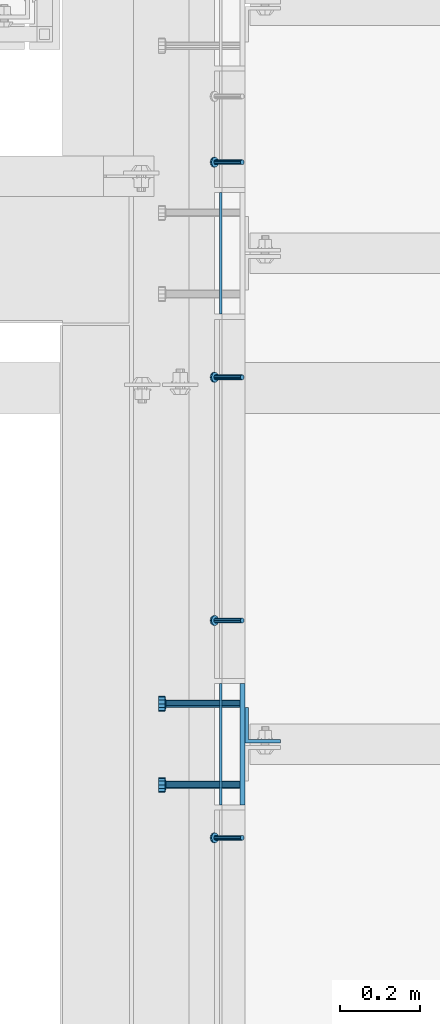
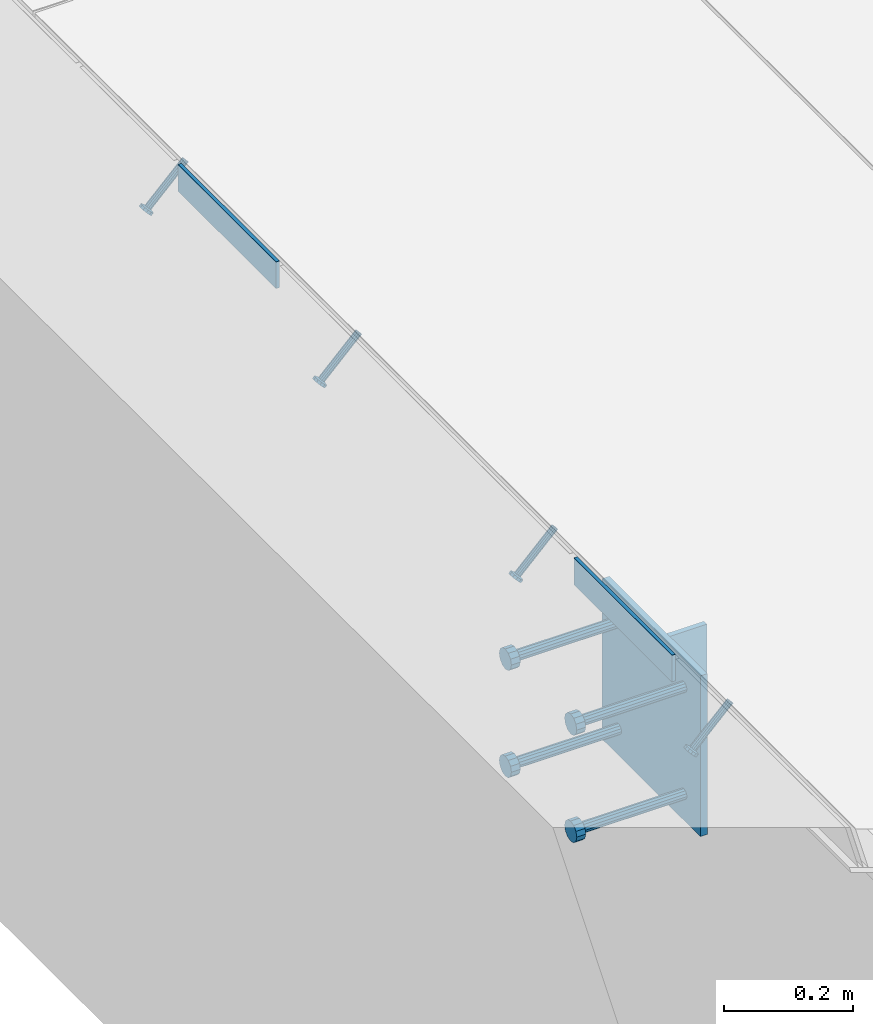
# One storey, part 2074 of 3843: 8 beams, 4 members, 6 elements without a shape of their own.
"""IFC2X3 building model written with IfcOpenShell, lengths in millimetres."""

from ifc_helpers import new_model, si_unit, frame, origin_with_axes, place, context, subcontext, project, spatial, faceted_brep, material, type_object, element, aggregate, save


model = new_model("IFC2X3")

# Units and contexts
model_context = context("Model", 3, precision=1e-05, world=origin_with_axes())
body_context = subcontext(model_context, "Body", "Model", "MODEL_VIEW")
ifc_project = project(units=[si_unit("LENGTHUNIT", "METRE", prefix="MILLI"), si_unit("AREAUNIT", "SQUARE_METRE"), si_unit("VOLUMEUNIT", "CUBIC_METRE"), si_unit("MASSUNIT", "GRAM", prefix="KILO"), si_unit("TIMEUNIT", "SECOND"), si_unit("PLANEANGLEUNIT", "RADIAN"), si_unit("SOLIDANGLEUNIT", "STERADIAN"), si_unit("THERMODYNAMICTEMPERATUREUNIT", "DEGREE_CELSIUS"), si_unit("LUMINOUSINTENSITYUNIT", "LUMEN")], contexts=[model_context])

# Site, building, storey
site_placement = place(None, origin_with_axes())
site = spatial("IfcSite", under=ifc_project, at=site_placement, CompositionType="ELEMENT")
building_placement = place(site_placement, origin_with_axes())
building = spatial("IfcBuilding", under=site, at=building_placement, Name="Undefined", CompositionType="ELEMENT")
storey_placement = place(building_placement, origin_with_axes())
storey = spatial("IfcBuildingStorey", under=building, at=storey_placement, Name="Undefined", CompositionType="ELEMENT", Elevation=0.0)

# Assembly, beam
assembly_1_placement = place(storey_placement, origin_with_axes())
assembly_1 = element("IfcElementAssembly", 1, at=assembly_1_placement, inside=storey, Name="EMBED PLATE", AssemblyPlace="NOTDEFINED", PredefinedType="RIGID_FRAME")
ifc_material_1 = material(Name="STEEL/A36")
beam_type_1 = type_object("IfcBeamType", PredefinedType="NOTDEFINED")
beam_1_placement = place(assembly_1_placement, frame((56080.0250030518, 17306.925, 30454.6), z_axis=(0.0, 0.0, 1.0), x_axis=(0.0, 1.0, 0.0)))
beam_1 = element("IfcBeam", 2, at=beam_1_placement, type_object=beam_type_1, material=ifc_material_1, Name="PLATE", context=body_context, shape_type="Brep", body=[
    faceted_brep([(0.0, 3.17499999999927, -25.4000000000015), (0.0, 3.17499999999927, 25.4000000000015), (304.800000000003, 3.17500000000291, 25.4000000000015), (304.800000000003, 3.17500000000291, -25.4000000000015), (0.0, -3.17499999999927, 25.4000000000015), (304.800000000003, -3.17500000000291, 25.4000000000015), (0.0, -3.17499999999927, -25.4000000000015), (304.800000000003, -3.17500000000291, -25.4000000000015)], [[[0, 1, 2, 3]], [[1, 4, 5, 2]], [[4, 6, 7, 5]], [[6, 0, 3, 7]], [[5, 7, 3, 2]], [[6, 4, 1, 0]]]),
])
aggregate(assembly_1, [beam_1])

assembly_2_placement = place(storey_placement, origin_with_axes())
assembly_2 = element("IfcElementAssembly", 3, at=assembly_2_placement, inside=storey, Name="EMBED PLATE", AssemblyPlace="NOTDEFINED", PredefinedType="RIGID_FRAME")
beam_2_placement = place(assembly_2_placement, frame((56080.0250030517, 16076.6125, 30454.6), z_axis=(0.0, 0.0, 1.0), x_axis=(0.0, 1.0, 0.0)))
beam_2 = element("IfcBeam", 4, at=beam_2_placement, type_object=beam_type_1, material=ifc_material_1, Name="PLATE", context=body_context, shape_type="Brep", body=[
    faceted_brep([(0.0, 3.17499999999927, -25.4000000000015), (0.0, 3.17499999999927, 25.4000000000015), (304.800000000003, 3.17500000000291, 25.4000000000015), (304.800000000003, 3.17500000000291, -25.4000000000015), (0.0, -3.17499999999927, 25.4000000000015), (304.800000000003, -3.17500000000291, 25.4000000000015), (0.0, -3.17499999999927, -25.4000000000015), (304.800000000003, -3.17500000000291, -25.4000000000015)], [[[0, 1, 2, 3]], [[1, 4, 5, 2]], [[4, 6, 7, 5]], [[6, 0, 3, 7]], [[5, 7, 3, 2]], [[6, 4, 1, 0]]]),
])

# Assembly, member
assembly_3_placement = place(storey_placement, origin_with_axes())
assembly_3 = element("IfcElementAssembly", 5, at=assembly_3_placement, inside=storey, Name="ANGLE", AssemblyPlace="NOTDEFINED", PredefinedType="RIGID_FRAME")
ifc_material_2 = material(Name="STEEL/A108")
member_type = type_object("IfcMemberType", PredefinedType="NOTDEFINED")
member_1_placement = place(assembly_3_placement, frame((56134.0000007283, 17687.9250728612, 30422.8500045777), z_axis=(0.0, -1.0, 0.0), x_axis=(-0.707106781186548, 0.0, -0.707106781186548)))
member_1 = element("IfcMember", 6, at=member_1_placement, type_object=member_type, material=ifc_material_2, Name="HEADED STUD ANCHOR", context=body_context, shape_type="Brep", body=[
    faceted_brep([(7.27595761418343e-12, -3.18000006675175, 5.5), (0.0, -5.49999999998363, 3.1800000667572), (94.4879985803855, -5.50000000011278, 3.1800000667572), (94.4879985803782, -3.18000006687362, 5.5), (0.0, -6.3499999046162, 0.0), (94.4879985803855, -6.34999990474535, 0.0), (0.0, -5.49999999998363, -3.1800000667572), (94.4879985803855, -5.50000000011278, -3.1800000667572), (7.27595761418343e-12, -3.18000006675175, -5.5), (94.4879985803782, -3.18000006687362, -5.5), (7.27595761418343e-12, -1.81898940354586e-12, -6.34999990463257), (94.4879985803782, -1.20053300634027e-10, -6.34999990463257), (0.0, 3.18000006675175, -5.5), (94.4879985803709, 3.18000006663351, -5.5), (7.27595761418343e-12, 5.49999999998363, -3.1800000667572), (94.4879985803709, 5.49999999987267, -3.1800000667572), (7.27595761418343e-12, 6.3499999046162, 0.0), (94.4879985803673, 6.34999990450706, 0.0), (7.27595761418343e-12, 5.49999999998363, 3.1800000667572), (94.4879985803709, 5.49999999987267, 3.1800000667572), (0.0, 3.18000006675175, 5.5), (94.4879985803709, 3.18000006663351, 5.5), (7.27595761418343e-12, -1.81898940354586e-12, 6.34999990463257), (94.4879985803782, -1.20053300634027e-10, 6.34999990463257), (96.5199985498621, -10.9899997712273, 6.34999990463257), (96.5199985498548, -6.34000015270249, 10.9899997711182), (96.5199985498621, -12.6999998093743, 0.0), (96.5199985498621, -10.9899997712273, -6.34999990463257), (96.5199985498548, -6.34000015270249, -10.9899997711182), (96.5199985498475, -1.21872290037572e-10, -12.6899995803833), (96.5199985498402, 6.34000015245874, -10.9899997711182), (96.519998549833, 10.9899997709817, -6.34999990463257), (96.519998549833, 12.6999998091305, 0.0), (96.519998549833, 10.9899997709817, 6.34999990463257), (96.5199985498402, 6.34000015245874, 10.9899997711182), (96.5199985498475, -1.21872290037572e-10, 12.6899995803833), (101.599998473539, -10.9899997712328, 6.34999990463257), (101.599998473532, -6.34000015270976, 10.9899997711182), (101.599998473539, -12.6999998093797, 0.0), (101.599998473539, -10.9899997712328, -6.34999990463257), (101.599998473532, -6.34000015270976, -10.9899997711182), (101.599998473524, -1.29148247651756e-10, -12.6899995803833), (101.599998473517, 6.34000015245329, -10.9899997711182), (101.59999847351, 10.9899997709763, -6.34999990463257), (101.599998473503, 12.6999998091196, 0.0), (101.59999847351, 10.9899997709763, 6.34999990463257), (101.599998473517, 6.34000015245329, 10.9899997711182), (101.599998473524, -1.29148247651756e-10, 12.6899995803833)], [[[0, 1, 2, 3]], [[1, 4, 5, 2]], [[4, 6, 7, 5]], [[6, 8, 9, 7]], [[8, 10, 11, 9]], [[10, 12, 13, 11]], [[12, 14, 15, 13]], [[14, 16, 17, 15]], [[16, 18, 19, 17]], [[18, 20, 21, 19]], [[20, 22, 23, 21]], [[22, 0, 3, 23]], [[22, 20, 18, 16, 14, 12, 10, 8, 6, 4, 1, 0]], [[3, 2, 24, 25]], [[2, 5, 26, 24]], [[5, 7, 27, 26]], [[7, 9, 28, 27]], [[9, 11, 29, 28]], [[11, 13, 30, 29]], [[13, 15, 31, 30]], [[15, 17, 32, 31]], [[17, 19, 33, 32]], [[19, 21, 34, 33]], [[21, 23, 35, 34]], [[23, 3, 25, 35]], [[25, 24, 36, 37]], [[24, 26, 38, 36]], [[26, 27, 39, 38]], [[27, 28, 40, 39]], [[28, 29, 41, 40]], [[29, 30, 42, 41]], [[30, 31, 43, 42]], [[31, 32, 44, 43]], [[32, 33, 45, 44]], [[33, 34, 46, 45]], [[34, 35, 47, 46]], [[35, 25, 37, 47]], [[38, 39, 40, 41, 42, 43, 44, 45, 46, 47, 37, 36]]]),
])
aggregate(assembly_3, [member_1])

# Assembly, members
assembly_4_placement = place(storey_placement, origin_with_axes())
assembly_4 = element("IfcElementAssembly", 7, at=assembly_4_placement, inside=storey, Name="ANGLE", AssemblyPlace="NOTDEFINED", PredefinedType="RIGID_FRAME")
member_2_placement = place(assembly_4_placement, frame((56133.999995567, 17148.9683662545, 30422.8500045777), z_axis=(0.0, -1.0, 0.0), x_axis=(-0.707106781186548, 0.0, -0.707106781186548)))
member_2 = element("IfcMember", 8, at=member_2_placement, type_object=member_type, material=ifc_material_2, Name="HEADED STUD ANCHOR", context=body_context, shape_type="Brep", body=[
    faceted_brep([(7.27595761418343e-12, -3.18000006675175, 5.5), (0.0, -5.49999999998363, 3.1800000667572), (94.4879985803855, -5.50000000011278, 3.1800000667572), (94.4879985803782, -3.18000006687362, 5.5), (0.0, -6.3499999046162, 0.0), (94.4879985803855, -6.34999990474535, 0.0), (0.0, -5.49999999998363, -3.1800000667572), (94.4879985803855, -5.50000000011278, -3.1800000667572), (7.27595761418343e-12, -3.18000006675175, -5.5), (94.4879985803782, -3.18000006687362, -5.5), (7.27595761418343e-12, -1.81898940354586e-12, -6.34999990463257), (94.4879985803782, -1.20053300634027e-10, -6.34999990463257), (0.0, 3.18000006675175, -5.5), (94.4879985803709, 3.18000006663351, -5.5), (7.27595761418343e-12, 5.49999999998363, -3.1800000667572), (94.4879985803709, 5.49999999987267, -3.1800000667572), (7.27595761418343e-12, 6.3499999046162, 0.0), (94.4879985803673, 6.34999990450706, 0.0), (7.27595761418343e-12, 5.49999999998363, 3.1800000667572), (94.4879985803709, 5.49999999987267, 3.1800000667572), (0.0, 3.18000006675175, 5.5), (94.4879985803709, 3.18000006663351, 5.5), (7.27595761418343e-12, -1.81898940354586e-12, 6.34999990463257), (94.4879985803782, -1.20053300634027e-10, 6.34999990463257), (96.5199985498621, -10.9899997712273, 6.34999990463257), (96.5199985498548, -6.34000015270249, 10.9899997711182), (96.5199985498621, -12.6999998093743, 0.0), (96.5199985498621, -10.9899997712273, -6.34999990463257), (96.5199985498548, -6.34000015270249, -10.9899997711182), (96.5199985498475, -1.21872290037572e-10, -12.6899995803833), (96.5199985498402, 6.34000015245874, -10.9899997711182), (96.519998549833, 10.9899997709817, -6.34999990463257), (96.519998549833, 12.6999998091305, 0.0), (96.519998549833, 10.9899997709817, 6.34999990463257), (96.5199985498402, 6.34000015245874, 10.9899997711182), (96.5199985498475, -1.21872290037572e-10, 12.6899995803833), (101.599998473539, -10.9899997712328, 6.34999990463257), (101.599998473532, -6.34000015270976, 10.9899997711182), (101.599998473539, -12.6999998093797, 0.0), (101.599998473539, -10.9899997712328, -6.34999990463257), (101.599998473532, -6.34000015270976, -10.9899997711182), (101.599998473524, -1.29148247651756e-10, -12.6899995803833), (101.599998473517, 6.34000015245329, -10.9899997711182), (101.59999847351, 10.9899997709763, -6.34999990463257), (101.599998473503, 12.6999998091196, 0.0), (101.59999847351, 10.9899997709763, 6.34999990463257), (101.599998473517, 6.34000015245329, 10.9899997711182), (101.599998473524, -1.29148247651756e-10, 12.6899995803833)], [[[0, 1, 2, 3]], [[1, 4, 5, 2]], [[4, 6, 7, 5]], [[6, 8, 9, 7]], [[8, 10, 11, 9]], [[10, 12, 13, 11]], [[12, 14, 15, 13]], [[14, 16, 17, 15]], [[16, 18, 19, 17]], [[18, 20, 21, 19]], [[20, 22, 23, 21]], [[22, 0, 3, 23]], [[22, 20, 18, 16, 14, 12, 10, 8, 6, 4, 1, 0]], [[3, 2, 24, 25]], [[2, 5, 26, 24]], [[5, 7, 27, 26]], [[7, 9, 28, 27]], [[9, 11, 29, 28]], [[11, 13, 30, 29]], [[13, 15, 31, 30]], [[15, 17, 32, 31]], [[17, 19, 33, 32]], [[19, 21, 34, 33]], [[21, 23, 35, 34]], [[23, 3, 25, 35]], [[25, 24, 36, 37]], [[24, 26, 38, 36]], [[26, 27, 39, 38]], [[27, 28, 40, 39]], [[28, 29, 41, 40]], [[29, 30, 42, 41]], [[30, 31, 43, 42]], [[31, 32, 44, 43]], [[32, 33, 45, 44]], [[33, 34, 46, 45]], [[34, 35, 47, 46]], [[35, 25, 37, 47]], [[38, 39, 40, 41, 42, 43, 44, 45, 46, 47, 37, 36]]]),
])
member_3_placement = place(assembly_4_placement, frame((56133.999995567, 16539.3683662545, 30422.8500045777), z_axis=(0.0, -1.0, 0.0), x_axis=(-0.707106781186548, 0.0, -0.707106781186548)))
member_3 = element("IfcMember", 9, at=member_3_placement, type_object=member_type, material=ifc_material_2, Name="HEADED STUD ANCHOR", context=body_context, shape_type="Brep", body=[
    faceted_brep([(7.27595761418343e-12, -3.18000006675175, 5.5), (0.0, -5.49999999998363, 3.1800000667572), (94.4879985803855, -5.50000000011278, 3.1800000667572), (94.4879985803782, -3.18000006687362, 5.5), (0.0, -6.3499999046162, 0.0), (94.4879985803855, -6.34999990474535, 0.0), (0.0, -5.49999999998363, -3.1800000667572), (94.4879985803855, -5.50000000011278, -3.1800000667572), (7.27595761418343e-12, -3.18000006675175, -5.5), (94.4879985803782, -3.18000006687362, -5.5), (7.27595761418343e-12, -1.81898940354586e-12, -6.34999990463257), (94.4879985803782, -1.20053300634027e-10, -6.34999990463257), (0.0, 3.18000006675175, -5.5), (94.4879985803709, 3.18000006663351, -5.5), (7.27595761418343e-12, 5.49999999998363, -3.1800000667572), (94.4879985803709, 5.49999999987267, -3.1800000667572), (7.27595761418343e-12, 6.3499999046162, 0.0), (94.4879985803673, 6.34999990450706, 0.0), (7.27595761418343e-12, 5.49999999998363, 3.1800000667572), (94.4879985803709, 5.49999999987267, 3.1800000667572), (0.0, 3.18000006675175, 5.5), (94.4879985803709, 3.18000006663351, 5.5), (7.27595761418343e-12, -1.81898940354586e-12, 6.34999990463257), (94.4879985803782, -1.20053300634027e-10, 6.34999990463257), (96.5199985498621, -10.9899997712273, 6.34999990463257), (96.5199985498548, -6.34000015270249, 10.9899997711182), (96.5199985498621, -12.6999998093743, 0.0), (96.5199985498621, -10.9899997712273, -6.34999990463257), (96.5199985498548, -6.34000015270249, -10.9899997711182), (96.5199985498475, -1.21872290037572e-10, -12.6899995803833), (96.5199985498402, 6.34000015245874, -10.9899997711182), (96.519998549833, 10.9899997709817, -6.34999990463257), (96.519998549833, 12.6999998091305, 0.0), (96.519998549833, 10.9899997709817, 6.34999990463257), (96.5199985498402, 6.34000015245874, 10.9899997711182), (96.5199985498475, -1.21872290037572e-10, 12.6899995803833), (101.599998473539, -10.9899997712328, 6.34999990463257), (101.599998473532, -6.34000015270976, 10.9899997711182), (101.599998473539, -12.6999998093797, 0.0), (101.599998473539, -10.9899997712328, -6.34999990463257), (101.599998473532, -6.34000015270976, -10.9899997711182), (101.599998473524, -1.29148247651756e-10, -12.6899995803833), (101.599998473517, 6.34000015245329, -10.9899997711182), (101.59999847351, 10.9899997709763, -6.34999990463257), (101.599998473503, 12.6999998091196, 0.0), (101.59999847351, 10.9899997709763, 6.34999990463257), (101.599998473517, 6.34000015245329, 10.9899997711182), (101.599998473524, -1.29148247651756e-10, 12.6899995803833)], [[[0, 1, 2, 3]], [[1, 4, 5, 2]], [[4, 6, 7, 5]], [[6, 8, 9, 7]], [[8, 10, 11, 9]], [[10, 12, 13, 11]], [[12, 14, 15, 13]], [[14, 16, 17, 15]], [[16, 18, 19, 17]], [[18, 20, 21, 19]], [[20, 22, 23, 21]], [[22, 0, 3, 23]], [[22, 20, 18, 16, 14, 12, 10, 8, 6, 4, 1, 0]], [[3, 2, 24, 25]], [[2, 5, 26, 24]], [[5, 7, 27, 26]], [[7, 9, 28, 27]], [[9, 11, 29, 28]], [[11, 13, 30, 29]], [[13, 15, 31, 30]], [[15, 17, 32, 31]], [[17, 19, 33, 32]], [[19, 21, 34, 33]], [[21, 23, 35, 34]], [[23, 3, 25, 35]], [[25, 24, 36, 37]], [[24, 26, 38, 36]], [[26, 27, 39, 38]], [[27, 28, 40, 39]], [[28, 29, 41, 40]], [[29, 30, 42, 41]], [[30, 31, 43, 42]], [[31, 32, 44, 43]], [[32, 33, 45, 44]], [[33, 34, 46, 45]], [[34, 35, 47, 46]], [[35, 25, 37, 47]], [[38, 39, 40, 41, 42, 43, 44, 45, 46, 47, 37, 36]]]),
])
aggregate(assembly_4, [member_2, member_3])

# Assembly, member
assembly_5_placement = place(storey_placement, origin_with_axes())
assembly_5 = element("IfcElementAssembly", 10, at=assembly_5_placement, inside=storey, Name="ANGLE", AssemblyPlace="NOTDEFINED", PredefinedType="RIGID_FRAME")
member_4_placement = place(assembly_5_placement, frame((56133.9999890706, 15994.8559998001, 30422.8500045777), z_axis=(0.0, -1.0, 0.0), x_axis=(-0.707106781186548, 0.0, -0.707106781186548)))
member_4 = element("IfcMember", 11, at=member_4_placement, type_object=member_type, material=ifc_material_2, Name="HEADED STUD ANCHOR", context=body_context, shape_type="Brep", body=[
    faceted_brep([(7.27595761418343e-12, -3.18000006675175, 5.5), (0.0, -5.49999999998363, 3.1800000667572), (94.4879985803855, -5.50000000011278, 3.1800000667572), (94.4879985803782, -3.18000006687362, 5.5), (0.0, -6.3499999046162, 0.0), (94.4879985803855, -6.34999990474535, 0.0), (0.0, -5.49999999998363, -3.1800000667572), (94.4879985803855, -5.50000000011278, -3.1800000667572), (7.27595761418343e-12, -3.18000006675175, -5.5), (94.4879985803782, -3.18000006687362, -5.5), (7.27595761418343e-12, -1.81898940354586e-12, -6.34999990463257), (94.4879985803782, -1.20053300634027e-10, -6.34999990463257), (0.0, 3.18000006675175, -5.5), (94.4879985803709, 3.18000006663351, -5.5), (7.27595761418343e-12, 5.49999999998363, -3.1800000667572), (94.4879985803709, 5.49999999987267, -3.1800000667572), (7.27595761418343e-12, 6.3499999046162, 0.0), (94.4879985803673, 6.34999990450706, 0.0), (7.27595761418343e-12, 5.49999999998363, 3.1800000667572), (94.4879985803709, 5.49999999987267, 3.1800000667572), (0.0, 3.18000006675175, 5.5), (94.4879985803709, 3.18000006663351, 5.5), (7.27595761418343e-12, -1.81898940354586e-12, 6.34999990463257), (94.4879985803782, -1.20053300634027e-10, 6.34999990463257), (96.5199985498621, -10.9899997712273, 6.34999990463257), (96.5199985498548, -6.34000015270249, 10.9899997711182), (96.5199985498621, -12.6999998093743, 0.0), (96.5199985498621, -10.9899997712273, -6.34999990463257), (96.5199985498548, -6.34000015270249, -10.9899997711182), (96.5199985498475, -1.21872290037572e-10, -12.6899995803833), (96.5199985498402, 6.34000015245874, -10.9899997711182), (96.519998549833, 10.9899997709817, -6.34999990463257), (96.519998549833, 12.6999998091305, 0.0), (96.519998549833, 10.9899997709817, 6.34999990463257), (96.5199985498402, 6.34000015245874, 10.9899997711182), (96.5199985498475, -1.21872290037572e-10, 12.6899995803833), (101.599998473539, -10.9899997712328, 6.34999990463257), (101.599998473532, -6.34000015270976, 10.9899997711182), (101.599998473539, -12.6999998093797, 0.0), (101.599998473539, -10.9899997712328, -6.34999990463257), (101.599998473532, -6.34000015270976, -10.9899997711182), (101.599998473524, -1.29148247651756e-10, -12.6899995803833), (101.599998473517, 6.34000015245329, -10.9899997711182), (101.59999847351, 10.9899997709763, -6.34999990463257), (101.599998473503, 12.6999998091196, 0.0), (101.59999847351, 10.9899997709763, 6.34999990463257), (101.599998473517, 6.34000015245329, 10.9899997711182), (101.599998473524, -1.29148247651756e-10, 12.6899995803833)], [[[0, 1, 2, 3]], [[1, 4, 5, 2]], [[4, 6, 7, 5]], [[6, 8, 9, 7]], [[8, 10, 11, 9]], [[10, 12, 13, 11]], [[12, 14, 15, 13]], [[14, 16, 17, 15]], [[16, 18, 19, 17]], [[18, 20, 21, 19]], [[20, 22, 23, 21]], [[22, 0, 3, 23]], [[22, 20, 18, 16, 14, 12, 10, 8, 6, 4, 1, 0]], [[3, 2, 24, 25]], [[2, 5, 26, 24]], [[5, 7, 27, 26]], [[7, 9, 28, 27]], [[9, 11, 29, 28]], [[11, 13, 30, 29]], [[13, 15, 31, 30]], [[15, 17, 32, 31]], [[17, 19, 33, 32]], [[19, 21, 34, 33]], [[21, 23, 35, 34]], [[23, 3, 25, 35]], [[25, 24, 36, 37]], [[24, 26, 38, 36]], [[26, 27, 39, 38]], [[27, 28, 40, 39]], [[28, 29, 41, 40]], [[29, 30, 42, 41]], [[30, 31, 43, 42]], [[31, 32, 44, 43]], [[32, 33, 45, 44]], [[33, 34, 46, 45]], [[34, 35, 47, 46]], [[35, 25, 37, 47]], [[38, 39, 40, 41, 42, 43, 44, 45, 46, 47, 37, 36]]]),
])
aggregate(assembly_5, [member_4])

# Beam
beam_type_2 = type_object("IfcBeamType", PredefinedType="NOTDEFINED")
beam_3_placement = place(assembly_2_placement, frame((56134.0000030517, 16229.0125, 30422.85), z_axis=(0.0, 1.0, 0.0), x_axis=(0.0, 0.0, -1.0)))
beam_3 = element("IfcBeam", 12, at=beam_3_placement, type_object=beam_type_2, material=ifc_material_1, Name="EMBED PLATE", context=body_context, shape_type="Brep", body=[
    faceted_brep([(-1.0550138540566e-10, 6.34999999999854, -152.400000000664), (1.0550138540566e-10, 6.34999999999854, 152.400000000656), (304.799999999999, 6.34999999999854, 152.400000000001), (304.799999999999, 6.34999999999854, -152.400000000001), (1.0550138540566e-10, -6.34999999999854, 152.400000000656), (304.799999999999, -6.34999999999854, 152.400000000001), (-1.0550138540566e-10, -6.34999999999854, -152.400000000664), (304.799999999999, -6.34999999999854, -152.400000000001)], [[[0, 1, 2, 3]], [[1, 4, 5, 2]], [[4, 6, 7, 5]], [[6, 0, 3, 7]], [[5, 7, 3, 2]], [[6, 4, 1, 0]]]),
])

# Assembly, beam
assembly_6_placement = place(storey_placement, origin_with_axes())
assembly_6 = element("IfcElementAssembly", 13, at=assembly_6_placement, inside=storey, Name="BEAM", AssemblyPlace="NOTDEFINED", PredefinedType="RIGID_FRAME")
beam_type_3 = type_object("IfcBeamType", Name="L3-1/2X3-1/2X3/8", PredefinedType="NOTDEFINED")
beam_4_placement = place(assembly_6_placement, frame((56184.8000030518, 16276.6375, 30391.1), z_axis=(0.0, 1.0, 0.0), x_axis=(0.0, 0.0, -1.0)))
beam_4 = element("IfcBeam", 14, at=beam_4_placement, type_object=beam_type_3, material=ifc_material_1, Name="ANGLE", ObjectType="L3-1/2X3-1/2X3/8", context=body_context, shape_type="Brep", body=[
    faceted_brep([(-3.63797880709171e-12, 44.4499999999971, -44.4500000000007), (-3.63797880709171e-12, 44.4499999999971, 44.4500000000007), (228.600000000006, 44.4499999999971, 44.4500000000007), (228.600000000006, 44.4499999999971, -44.4500000000007), (0.0, 34.9250000000029, 44.4500000000007), (228.600000000006, 34.9250000000029, 44.4500000000007), (0.0, 34.9250000000029, -34.9250000000029), (228.600000000006, 34.9250000000029, -34.9249999999993), (0.0, -44.4499999999971, -34.9249999999993), (228.600000000006, -44.4499999999971, -34.9249999999993), (3.63797880709171e-12, -44.4499999999971, -44.4500000000007), (228.600000000006, -44.4499999999971, -44.4500000000007)], [[[0, 1, 2, 3]], [[1, 4, 5, 2]], [[4, 6, 7, 5]], [[6, 8, 9, 7]], [[8, 10, 11, 9]], [[10, 0, 3, 11]], [[5, 7, 9, 11, 3, 2]], [[10, 8, 6, 4, 1, 0]]]),
])
aggregate(assembly_6, [beam_4])

# Beam
beam_type_4 = type_object("IfcBeamType", PredefinedType="NOTDEFINED")
beam_5_placement = place(assembly_2_placement, frame((56127.6500030517, 16127.4125, 30372.05), z_axis=(0.0, -1.0, 0.0), x_axis=(-1.0, 0.0, 0.0)))
beam_5 = element("IfcBeam", 15, at=beam_5_placement, type_object=beam_type_4, material=ifc_material_2, Name="HEADED STUD ANCHOR", context=body_context, shape_type="Brep", body=[
    faceted_brep([(0.0, -9.52000045776367, 0.0), (0.0, -8.25, -4.76000022888184), (184.912000000004, -8.25, -4.76000022888184), (184.912000000004, -9.52000045776367, 0.0), (0.0, -4.76000022888184, -8.25), (184.912000000004, -4.76000022888184, -8.25), (0.0, 0.0, -9.52000045776367), (184.912000000004, 0.0, -9.52000045776367), (0.0, 4.76000022888184, -8.25), (184.912000000004, 4.76000022888184, -8.25), (0.0, 8.25, -4.76000022888184), (184.912000000004, 8.25, -4.76000022888184), (0.0, 9.52000045776367, 0.0), (184.912000000004, 9.52000045776367, 0.0), (0.0, 8.25, 4.76000022888184), (184.912000000004, 8.25, 4.76000022888184), (0.0, 4.76000022888184, 8.25), (184.912000000004, 4.76000022888184, 8.25), (0.0, 0.0, 9.52000045776367), (184.912000000004, 0.0, 9.52000045776367), (0.0, -4.76000022888184, 8.25), (184.912000000004, -4.76000022888184, 8.25), (0.0, -8.25, 4.76000022888184), (184.912000000004, -8.25, 4.76000022888184), (186.944000000003, -16.5, -9.52000045776367), (186.944000000003, -19.0499992370605, 0.0), (186.944000000003, -9.52000045776367, -16.5), (186.944000000003, 0.0, -19.0499992370605), (186.944000000003, 9.52000045776367, -16.5), (186.944000000003, 16.5, -9.52000045776367), (186.944000000003, 19.0499992370605, 0.0), (186.944000000003, 16.5, 9.52000045776367), (186.944000000003, 9.52000045776367, 16.5), (186.944000000003, 0.0, 19.0499992370605), (186.944000000003, -9.52000045776367, 16.5), (186.944000000003, -16.5, 9.52000045776367), (203.199999999997, -16.5, -9.52000045776367), (203.199999999997, -19.0499992370605, 0.0), (203.199999999997, -9.52000045776367, -16.5), (203.199999999997, 0.0, -19.0499992370605), (203.199999999997, 9.52000045776367, -16.5), (203.199999999997, 16.5, -9.52000045776367), (203.199999999997, 19.0499992370605, 0.0), (203.199999999997, 16.5, 9.52000045776367), (203.199999999997, 9.52000045776367, 16.5), (203.199999999997, 0.0, 19.0499992370605), (203.199999999997, -9.52000045776367, 16.5), (203.199999999997, -16.5, 9.52000045776367)], [[[0, 1, 2, 3]], [[1, 4, 5, 2]], [[4, 6, 7, 5]], [[6, 8, 9, 7]], [[8, 10, 11, 9]], [[10, 12, 13, 11]], [[12, 14, 15, 13]], [[14, 16, 17, 15]], [[16, 18, 19, 17]], [[18, 20, 21, 19]], [[20, 22, 23, 21]], [[22, 0, 3, 23]], [[22, 20, 18, 16, 14, 12, 10, 8, 6, 4, 1, 0]], [[3, 2, 24, 25]], [[2, 5, 26, 24]], [[5, 7, 27, 26]], [[7, 9, 28, 27]], [[9, 11, 29, 28]], [[11, 13, 30, 29]], [[13, 15, 31, 30]], [[15, 17, 32, 31]], [[17, 19, 33, 32]], [[19, 21, 34, 33]], [[21, 23, 35, 34]], [[23, 3, 25, 35]], [[25, 24, 36, 37]], [[24, 26, 38, 36]], [[26, 27, 39, 38]], [[27, 28, 40, 39]], [[28, 29, 41, 40]], [[29, 30, 42, 41]], [[30, 31, 43, 42]], [[31, 32, 44, 43]], [[32, 33, 45, 44]], [[33, 34, 46, 45]], [[34, 35, 47, 46]], [[35, 25, 37, 47]], [[38, 39, 40, 41, 42, 43, 44, 45, 46, 47, 37, 36]]]),
])

beam_6_placement = place(assembly_2_placement, frame((56127.6500030517, 16127.4125, 30168.85), z_axis=(0.0, -1.0, 0.0), x_axis=(-1.0, 0.0, 0.0)))
beam_6 = element("IfcBeam", 16, at=beam_6_placement, type_object=beam_type_4, material=ifc_material_2, Name="HEADED STUD ANCHOR", context=body_context, shape_type="Brep", body=[
    faceted_brep([(0.0, -9.52000045776367, 0.0), (0.0, -8.25, -4.76000022888184), (184.912000000004, -8.25, -4.76000022888184), (184.912000000004, -9.52000045776367, 0.0), (0.0, -4.76000022888184, -8.25), (184.912000000004, -4.76000022888184, -8.25), (0.0, 0.0, -9.52000045776367), (184.912000000004, 0.0, -9.52000045776367), (0.0, 4.76000022888184, -8.25), (184.912000000004, 4.76000022888184, -8.25), (0.0, 8.25, -4.76000022888184), (184.912000000004, 8.25, -4.76000022888184), (0.0, 9.52000045776367, 0.0), (184.912000000004, 9.52000045776367, 0.0), (0.0, 8.25, 4.76000022888184), (184.912000000004, 8.25, 4.76000022888184), (0.0, 4.76000022888184, 8.25), (184.912000000004, 4.76000022888184, 8.25), (0.0, 0.0, 9.52000045776367), (184.912000000004, 0.0, 9.52000045776367), (0.0, -4.76000022888184, 8.25), (184.912000000004, -4.76000022888184, 8.25), (0.0, -8.25, 4.76000022888184), (184.912000000004, -8.25, 4.76000022888184), (186.944000000003, -16.5, -9.52000045776367), (186.944000000003, -19.0499992370605, 0.0), (186.944000000003, -9.52000045776367, -16.5), (186.944000000003, 0.0, -19.0499992370605), (186.944000000003, 9.52000045776367, -16.5), (186.944000000003, 16.5, -9.52000045776367), (186.944000000003, 19.0499992370605, 0.0), (186.944000000003, 16.5, 9.52000045776367), (186.944000000003, 9.52000045776367, 16.5), (186.944000000003, 0.0, 19.0499992370605), (186.944000000003, -9.52000045776367, 16.5), (186.944000000003, -16.5, 9.52000045776367), (203.199999999997, -16.5, -9.52000045776367), (203.199999999997, -19.0499992370605, 0.0), (203.199999999997, -9.52000045776367, -16.5), (203.199999999997, 0.0, -19.0499992370605), (203.199999999997, 9.52000045776367, -16.5), (203.199999999997, 16.5, -9.52000045776367), (203.199999999997, 19.0499992370605, 0.0), (203.199999999997, 16.5, 9.52000045776367), (203.199999999997, 9.52000045776367, 16.5), (203.199999999997, 0.0, 19.0499992370605), (203.199999999997, -9.52000045776367, 16.5), (203.199999999997, -16.5, 9.52000045776367)], [[[0, 1, 2, 3]], [[1, 4, 5, 2]], [[4, 6, 7, 5]], [[6, 8, 9, 7]], [[8, 10, 11, 9]], [[10, 12, 13, 11]], [[12, 14, 15, 13]], [[14, 16, 17, 15]], [[16, 18, 19, 17]], [[18, 20, 21, 19]], [[20, 22, 23, 21]], [[22, 0, 3, 23]], [[22, 20, 18, 16, 14, 12, 10, 8, 6, 4, 1, 0]], [[3, 2, 24, 25]], [[2, 5, 26, 24]], [[5, 7, 27, 26]], [[7, 9, 28, 27]], [[9, 11, 29, 28]], [[11, 13, 30, 29]], [[13, 15, 31, 30]], [[15, 17, 32, 31]], [[17, 19, 33, 32]], [[19, 21, 34, 33]], [[21, 23, 35, 34]], [[23, 3, 25, 35]], [[25, 24, 36, 37]], [[24, 26, 38, 36]], [[26, 27, 39, 38]], [[27, 28, 40, 39]], [[28, 29, 41, 40]], [[29, 30, 42, 41]], [[30, 31, 43, 42]], [[31, 32, 44, 43]], [[32, 33, 45, 44]], [[33, 34, 46, 45]], [[34, 35, 47, 46]], [[35, 25, 37, 47]], [[38, 39, 40, 41, 42, 43, 44, 45, 46, 47, 37, 36]]]),
])

beam_7_placement = place(assembly_2_placement, frame((56127.6500030517, 16330.6125, 30372.05), z_axis=(0.0, -1.0, 0.0), x_axis=(-1.0, 0.0, 0.0)))
beam_7 = element("IfcBeam", 17, at=beam_7_placement, type_object=beam_type_4, material=ifc_material_1, Name="PLATE", context=body_context, shape_type="Brep", body=[
    faceted_brep([(0.0, -9.52000045776367, 0.0), (0.0, -8.25, -4.76000022888184), (184.912000000004, -8.25, -4.76000022888184), (184.912000000004, -9.52000045776367, 0.0), (0.0, -4.76000022888184, -8.25), (184.912000000004, -4.76000022888184, -8.25), (0.0, 0.0, -9.52000045776367), (184.912000000004, 0.0, -9.52000045776367), (0.0, 4.76000022888184, -8.25), (184.912000000004, 4.76000022888184, -8.25), (0.0, 8.25, -4.76000022888184), (184.912000000004, 8.25, -4.76000022888184), (0.0, 9.52000045776367, 0.0), (184.912000000004, 9.52000045776367, 0.0), (0.0, 8.25, 4.76000022888184), (184.912000000004, 8.25, 4.76000022888184), (0.0, 4.76000022888184, 8.25), (184.912000000004, 4.76000022888184, 8.25), (0.0, 0.0, 9.52000045776367), (184.912000000004, 0.0, 9.52000045776367), (0.0, -4.76000022888184, 8.25), (184.912000000004, -4.76000022888184, 8.25), (0.0, -8.25, 4.76000022888184), (184.912000000004, -8.25, 4.76000022888184), (186.944000000003, -16.5, -9.52000045776367), (186.944000000003, -19.0499992370605, 0.0), (186.944000000003, -9.52000045776367, -16.5), (186.944000000003, 0.0, -19.0499992370605), (186.944000000003, 9.52000045776367, -16.5), (186.944000000003, 16.5, -9.52000045776367), (186.944000000003, 19.0499992370605, 0.0), (186.944000000003, 16.5, 9.52000045776367), (186.944000000003, 9.52000045776367, 16.5), (186.944000000003, 0.0, 19.0499992370605), (186.944000000003, -9.52000045776367, 16.5), (186.944000000003, -16.5, 9.52000045776367), (203.199999999997, -16.5, -9.52000045776367), (203.199999999997, -19.0499992370605, 0.0), (203.199999999997, -9.52000045776367, -16.5), (203.199999999997, 0.0, -19.0499992370605), (203.199999999997, 9.52000045776367, -16.5), (203.199999999997, 16.5, -9.52000045776367), (203.199999999997, 19.0499992370605, 0.0), (203.199999999997, 16.5, 9.52000045776367), (203.199999999997, 9.52000045776367, 16.5), (203.199999999997, 0.0, 19.0499992370605), (203.199999999997, -9.52000045776367, 16.5), (203.199999999997, -16.5, 9.52000045776367)], [[[0, 1, 2, 3]], [[1, 4, 5, 2]], [[4, 6, 7, 5]], [[6, 8, 9, 7]], [[8, 10, 11, 9]], [[10, 12, 13, 11]], [[12, 14, 15, 13]], [[14, 16, 17, 15]], [[16, 18, 19, 17]], [[18, 20, 21, 19]], [[20, 22, 23, 21]], [[22, 0, 3, 23]], [[22, 20, 18, 16, 14, 12, 10, 8, 6, 4, 1, 0]], [[3, 2, 24, 25]], [[2, 5, 26, 24]], [[5, 7, 27, 26]], [[7, 9, 28, 27]], [[9, 11, 29, 28]], [[11, 13, 30, 29]], [[13, 15, 31, 30]], [[15, 17, 32, 31]], [[17, 19, 33, 32]], [[19, 21, 34, 33]], [[21, 23, 35, 34]], [[23, 3, 25, 35]], [[25, 24, 36, 37]], [[24, 26, 38, 36]], [[26, 27, 39, 38]], [[27, 28, 40, 39]], [[28, 29, 41, 40]], [[29, 30, 42, 41]], [[30, 31, 43, 42]], [[31, 32, 44, 43]], [[32, 33, 45, 44]], [[33, 34, 46, 45]], [[34, 35, 47, 46]], [[35, 25, 37, 47]], [[38, 39, 40, 41, 42, 43, 44, 45, 46, 47, 37, 36]]]),
])

beam_8_placement = place(assembly_2_placement, frame((56127.6500030517, 16330.6125, 30168.85), z_axis=(0.0, -1.0, 0.0), x_axis=(-1.0, 0.0, 0.0)))
beam_8 = element("IfcBeam", 18, at=beam_8_placement, type_object=beam_type_4, material=ifc_material_2, Name="HEADED STUD ANCHOR", context=body_context, shape_type="Brep", body=[
    faceted_brep([(0.0, -9.52000045776367, 0.0), (0.0, -8.25, -4.76000022888184), (184.912000000004, -8.25, -4.76000022888184), (184.912000000004, -9.52000045776367, 0.0), (0.0, -4.76000022888184, -8.25), (184.912000000004, -4.76000022888184, -8.25), (0.0, 0.0, -9.52000045776367), (184.912000000004, 0.0, -9.52000045776367), (0.0, 4.76000022888184, -8.25), (184.912000000004, 4.76000022888184, -8.25), (0.0, 8.25, -4.76000022888184), (184.912000000004, 8.25, -4.76000022888184), (0.0, 9.52000045776367, 0.0), (184.912000000004, 9.52000045776367, 0.0), (0.0, 8.25, 4.76000022888184), (184.912000000004, 8.25, 4.76000022888184), (0.0, 4.76000022888184, 8.25), (184.912000000004, 4.76000022888184, 8.25), (0.0, 0.0, 9.52000045776367), (184.912000000004, 0.0, 9.52000045776367), (0.0, -4.76000022888184, 8.25), (184.912000000004, -4.76000022888184, 8.25), (0.0, -8.25, 4.76000022888184), (184.912000000004, -8.25, 4.76000022888184), (186.944000000003, -16.5, -9.52000045776367), (186.944000000003, -19.0499992370605, 0.0), (186.944000000003, -9.52000045776367, -16.5), (186.944000000003, 0.0, -19.0499992370605), (186.944000000003, 9.52000045776367, -16.5), (186.944000000003, 16.5, -9.52000045776367), (186.944000000003, 19.0499992370605, 0.0), (186.944000000003, 16.5, 9.52000045776367), (186.944000000003, 9.52000045776367, 16.5), (186.944000000003, 0.0, 19.0499992370605), (186.944000000003, -9.52000045776367, 16.5), (186.944000000003, -16.5, 9.52000045776367), (203.199999999997, -16.5, -9.52000045776367), (203.199999999997, -19.0499992370605, 0.0), (203.199999999997, -9.52000045776367, -16.5), (203.199999999997, 0.0, -19.0499992370605), (203.199999999997, 9.52000045776367, -16.5), (203.199999999997, 16.5, -9.52000045776367), (203.199999999997, 19.0499992370605, 0.0), (203.199999999997, 16.5, 9.52000045776367), (203.199999999997, 9.52000045776367, 16.5), (203.199999999997, 0.0, 19.0499992370605), (203.199999999997, -9.52000045776367, 16.5), (203.199999999997, -16.5, 9.52000045776367)], [[[0, 1, 2, 3]], [[1, 4, 5, 2]], [[4, 6, 7, 5]], [[6, 8, 9, 7]], [[8, 10, 11, 9]], [[10, 12, 13, 11]], [[12, 14, 15, 13]], [[14, 16, 17, 15]], [[16, 18, 19, 17]], [[18, 20, 21, 19]], [[20, 22, 23, 21]], [[22, 0, 3, 23]], [[22, 20, 18, 16, 14, 12, 10, 8, 6, 4, 1, 0]], [[3, 2, 24, 25]], [[2, 5, 26, 24]], [[5, 7, 27, 26]], [[7, 9, 28, 27]], [[9, 11, 29, 28]], [[11, 13, 30, 29]], [[13, 15, 31, 30]], [[15, 17, 32, 31]], [[17, 19, 33, 32]], [[19, 21, 34, 33]], [[21, 23, 35, 34]], [[23, 3, 25, 35]], [[25, 24, 36, 37]], [[24, 26, 38, 36]], [[26, 27, 39, 38]], [[27, 28, 40, 39]], [[28, 29, 41, 40]], [[29, 30, 42, 41]], [[30, 31, 43, 42]], [[31, 32, 44, 43]], [[32, 33, 45, 44]], [[33, 34, 46, 45]], [[34, 35, 47, 46]], [[35, 25, 37, 47]], [[38, 39, 40, 41, 42, 43, 44, 45, 46, 47, 37, 36]]]),
])

aggregate(assembly_2, [beam_2, beam_5, beam_6, beam_7, beam_8, beam_3])

save(model, "model.ifc")
